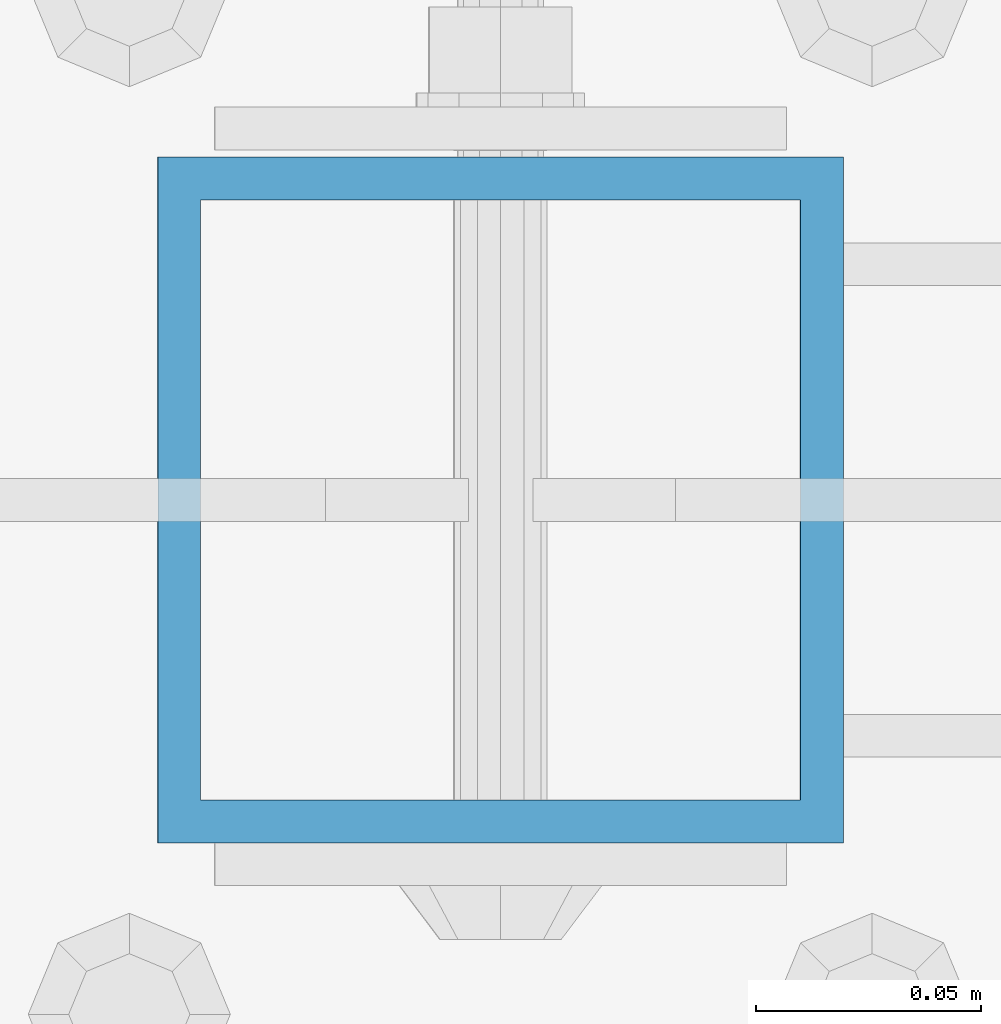
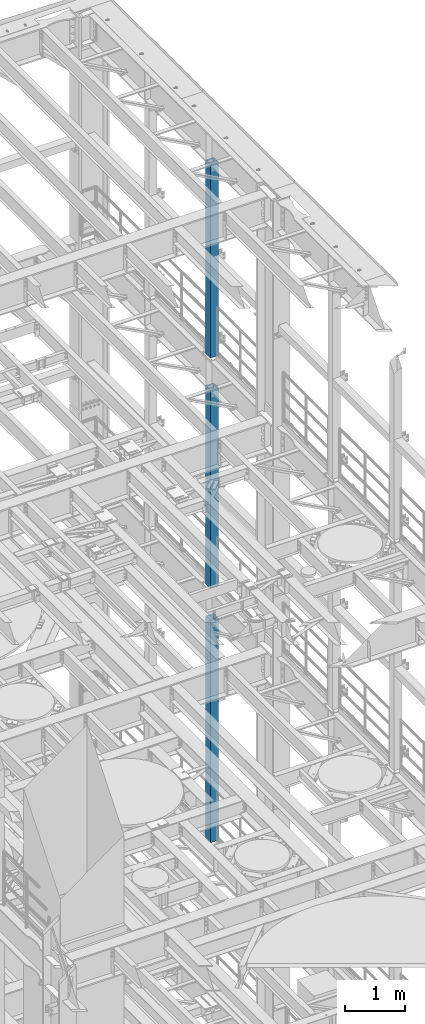
# One storey, part 763 of 1876: 3 columns, 3 elements without a shape of their own.
"""IFC2X3 building model written with IfcOpenShell, lengths in millimetres."""

from ifc_helpers import new_model, si_unit, frame, origin_with_axes, place, context, subcontext, project, spatial, faceted_brep, material, type_object, element, aggregate, save


model = new_model("IFC2X3")

# Units and contexts
model_context = context("Model", 3, precision=1e-05, world=origin_with_axes())
body_context = subcontext(model_context, "Body", "Model", "MODEL_VIEW")
ifc_project = project(units=[si_unit("LENGTHUNIT", "METRE", prefix="MILLI"), si_unit("AREAUNIT", "SQUARE_METRE"), si_unit("VOLUMEUNIT", "CUBIC_METRE"), si_unit("MASSUNIT", "GRAM", prefix="KILO"), si_unit("TIMEUNIT", "SECOND"), si_unit("PLANEANGLEUNIT", "RADIAN"), si_unit("SOLIDANGLEUNIT", "STERADIAN"), si_unit("THERMODYNAMICTEMPERATUREUNIT", "DEGREE_CELSIUS"), si_unit("LUMINOUSINTENSITYUNIT", "LUMEN")], contexts=[model_context])

# Site, building, storey
site_placement = place(None, origin_with_axes())
site = spatial("IfcSite", under=ifc_project, at=site_placement, CompositionType="ELEMENT")
building_placement = place(site_placement, origin_with_axes())
building = spatial("IfcBuilding", under=site, at=building_placement, Name="Undefined", CompositionType="ELEMENT")
storey_placement = place(building_placement, origin_with_axes())
storey = spatial("IfcBuildingStorey", under=building, at=storey_placement, Name="Undefined", CompositionType="ELEMENT", Elevation=0.0)

# Assembly, column
assembly_1_placement = place(storey_placement, origin_with_axes())
assembly_1 = element("IfcElementAssembly", 1, at=assembly_1_placement, inside=storey, Name="BEAM", AssemblyPlace="NOTDEFINED", PredefinedType="RIGID_FRAME")
ifc_material = material()
column_type = type_object("IfcColumnType", Name="HSS6X6X3/8", PredefinedType="NOTDEFINED")
column_1_placement = place(assembly_1_placement, frame((7620.0, 9652.0, 17983.2), z_axis=(-1.0, 0.0, 0.0), x_axis=(0.0, 0.0, 1.0)))
column_1 = element("IfcColumn", 2, at=column_1_placement, type_object=column_type, material=ifc_material, Name="COLUMN", ObjectType="HSS6X6X3/8", context=body_context, shape_type="Brep", body=[
    faceted_brep([(12.7000000000016, 66.6750000000002, -66.6750000000002), (12.7000000000016, -66.6750000000002, -66.6750000000002), (3937.0, -66.6750000000002, -66.675), (3937.0, 66.6750000000002, -66.675), (12.7000000000016, -66.6750000000002, 66.6750000000002), (3937.0, -66.6750000000002, 66.675), (12.7000000000016, 66.6750000000002, 66.6750000000002), (3937.0, 66.6750000000002, 66.675), (12.7000000000016, 76.1999999999998, -76.1999999999998), (12.7000000000016, 76.1999999999998, 76.1999999999998), (3937.0, 76.1999999999998, 76.2), (3937.0, 76.1999999999998, -76.2), (12.7000000000016, -76.1999999999998, 76.1999999999998), (3937.0, -76.1999999999998, 76.2), (12.7000000000016, -76.1999999999998, -76.1999999999998), (3937.0, -76.1999999999998, -76.2)], [[[0, 1, 2, 3]], [[1, 4, 5, 2]], [[4, 6, 7, 5]], [[6, 0, 3, 7]], [[8, 9, 10, 11]], [[9, 12, 13, 10]], [[12, 14, 15, 13]], [[14, 8, 11, 15]], [[13, 15, 11, 10], [5, 7, 3, 2]], [[14, 12, 9, 8], [6, 4, 1, 0]]]),
])
aggregate(assembly_1, [column_1])

assembly_2_placement = place(storey_placement, origin_with_axes())
assembly_2 = element("IfcElementAssembly", 3, at=assembly_2_placement, inside=storey, Name="BEAM", AssemblyPlace="NOTDEFINED", PredefinedType="RIGID_FRAME")
column_2_placement = place(assembly_2_placement, frame((7620.0, 9652.0, 13309.6), z_axis=(-1.0, 0.0, 0.0), x_axis=(0.0, 0.0, 1.0)))
column_2 = element("IfcColumn", 4, at=column_2_placement, type_object=column_type, material=ifc_material, Name="COLUMN", ObjectType="HSS6X6X3/8", context=body_context, shape_type="Brep", body=[
    faceted_brep([(12.7000000000016, 66.6750000000002, -66.6750000000002), (12.7000000000016, -66.6750000000002, -66.6750000000002), (4038.6, -66.6750000000002, -66.675), (4038.6, 66.6750000000002, -66.675), (12.7000000000016, -66.6750000000002, 66.6750000000002), (4038.6, -66.6750000000002, 66.675), (12.7000000000016, 66.6750000000002, 66.6750000000002), (4038.6, 66.6750000000002, 66.675), (12.7000000000016, 76.1999999999998, -76.1999999999998), (12.7000000000016, 76.1999999999998, 76.1999999999998), (4038.6, 76.1999999999998, 76.2), (4038.6, 76.1999999999998, -76.2), (12.7000000000016, -76.1999999999998, 76.1999999999998), (4038.6, -76.1999999999998, 76.2), (12.7000000000016, -76.1999999999998, -76.1999999999998), (4038.6, -76.1999999999998, -76.2)], [[[0, 1, 2, 3]], [[1, 4, 5, 2]], [[4, 6, 7, 5]], [[6, 0, 3, 7]], [[8, 9, 10, 11]], [[9, 12, 13, 10]], [[12, 14, 15, 13]], [[14, 8, 11, 15]], [[13, 15, 11, 10], [5, 7, 3, 2]], [[14, 12, 9, 8], [6, 4, 1, 0]]]),
])
aggregate(assembly_2, [column_2])

assembly_3_placement = place(storey_placement, origin_with_axes())
assembly_3 = element("IfcElementAssembly", 5, at=assembly_3_placement, inside=storey, Name="BEAM", AssemblyPlace="NOTDEFINED", PredefinedType="RIGID_FRAME")
column_3_placement = place(assembly_3_placement, frame((7620.0, 9652.0, 8153.4), z_axis=(-0.999999999563517, 0.0, -2.95459999870218e-05), x_axis=(-2.95459999861759e-05, 0.0, 0.999999999563517)))
column_3 = element("IfcColumn", 6, at=column_3_placement, type_object=column_type, material=ifc_material, Name="COLUMN", ObjectType="HSS6X6X3/8", context=body_context, shape_type="Brep", body=[
    faceted_brep([(12.698030025992, 66.6750000000002, -66.675), (12.698030025992, -66.6750000000002, -66.675), (4521.2007045434, -66.6750000000002, -66.675), (4521.2007045434, 66.6750000000002, -66.675), (12.7019699850925, -66.6750000000002, 66.675), (4521.20070454334, -66.6750000000002, 66.675), (12.7019699850925, 66.6750000000002, 66.675), (4521.20070454334, 66.6750000000002, 66.675), (12.6977486003425, 76.1999999999998, -76.2), (12.7022514107421, 76.1999999999998, 76.2), (4521.20070454334, 76.1999999999998, 76.2), (4521.2007045434, 76.1999999999998, -76.2), (12.7022514107421, -76.1999999999998, 76.2), (4521.20070454334, -76.1999999999998, 76.2), (12.6977486003425, -76.1999999999998, -76.2), (4521.2007045434, -76.1999999999998, -76.2)], [[[0, 1, 2, 3]], [[1, 4, 5, 2]], [[4, 6, 7, 5]], [[6, 0, 3, 7]], [[8, 9, 10, 11]], [[9, 12, 13, 10]], [[12, 14, 15, 13]], [[14, 8, 11, 15]], [[13, 15, 11, 10], [5, 7, 3, 2]], [[14, 12, 9, 8], [6, 4, 1, 0]]]),
])
aggregate(assembly_3, [column_3])

save(model, "model.ifc")
